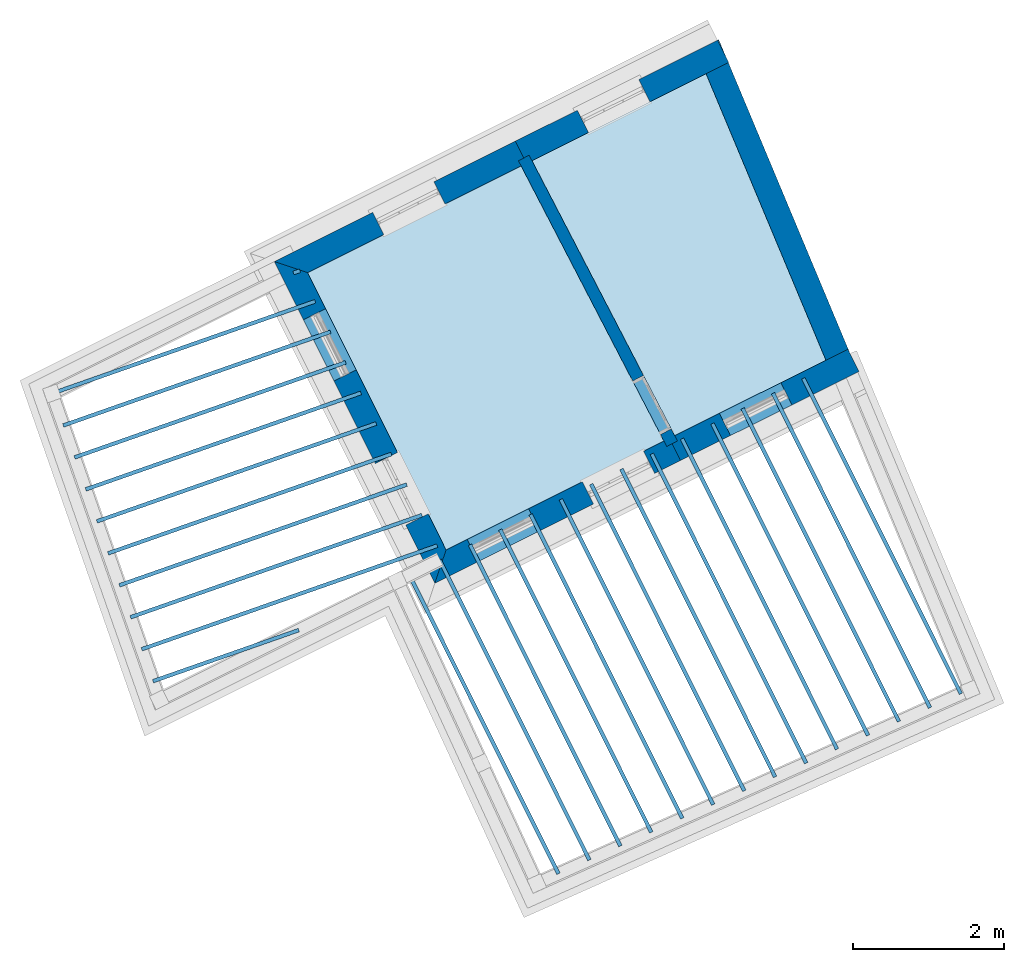
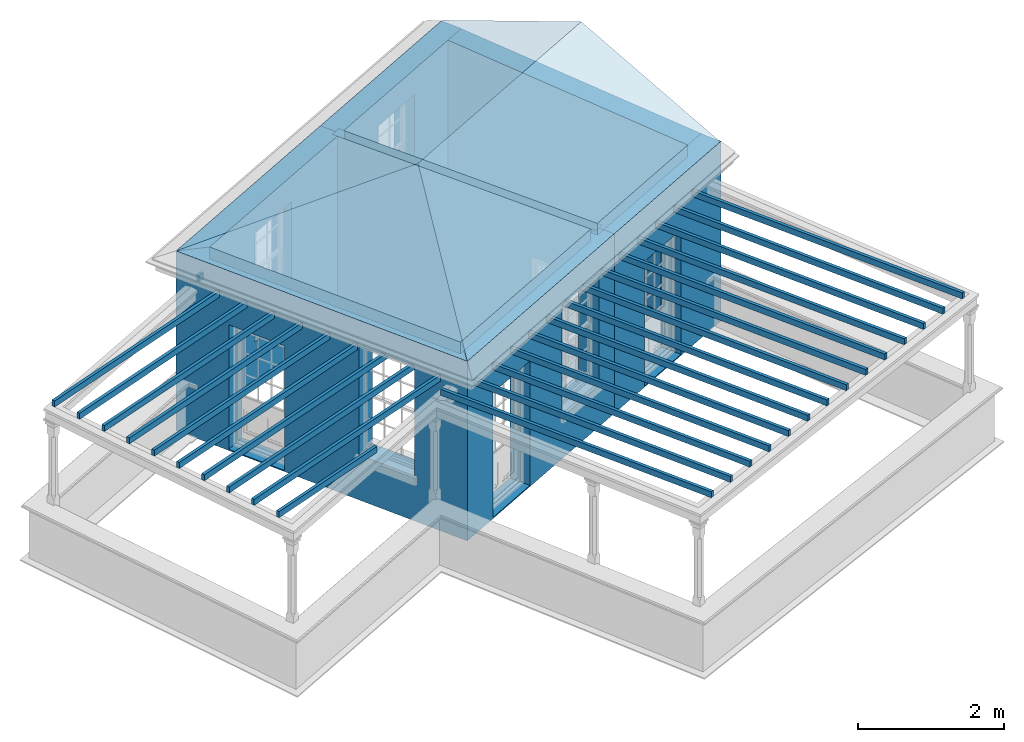
# One storey, part 1 of 7: 28 slabs, 7 walls, 1 roof, 8 openings.
"""IFC2X3 building model written with IfcOpenShell, lengths in metres."""

from ifc_helpers import new_model, si_unit, frame, origin, place, context, subcontext, project, spatial, polyline, outline, extrude, faceted_brep, material, layer, layer_set, layer_usage, element, save


model = new_model("IFC2X3")

# Units and contexts
model_context = context("Model", 3, world=origin())
body_context = subcontext(model_context, "Body", "Model", "MODEL_VIEW")
ifc_project = project(units=[si_unit("PLANEANGLEUNIT", "RADIAN"), si_unit("MASSUNIT", "GRAM", prefix="KILO"), si_unit("FORCEUNIT", "NEWTON", prefix="KILO"), si_unit("LENGTHUNIT", "METRE")], contexts=[model_context])

# Site, building, storey
site_placement = place(None, origin())
site = spatial("IfcSite", under=ifc_project, at=site_placement, CompositionType="ELEMENT")
building_placement = place(None, origin())
building = spatial("IfcBuilding", under=site, at=building_placement, Name="Building plot-8", CompositionType="ELEMENT")
storey_placement = place(None, frame((0.0, 0.0, 6.3)))
storey = spatial("IfcBuildingStorey", under=building, at=storey_placement, Name="Floor 2", CompositionType="ELEMENT", Elevation=6.3)

# Slabs
slab_1_placement = place(storey_placement, frame((0.0, 0.0, 2.8)))
element("IfcSlab", 1, at=slab_1_placement, inside=storey, Name="Slab", ObjectType="Slab", PredefinedType="FLOOR", context=body_context, shape_type="SweptSolid", body=[
    extrude(outline(polyline([(27.480706150414, 14.9772635263), (29.4890486291312, 15.9799160247855), (27.8974321953213, 19.7854722025051), (25.5844795437758, 18.6307449687159), (27.480706150414, 14.9772635263)])), origin(), (0.0, 0.0, 1.0), 0.2),
])
slab_2_placement = place(storey_placement, frame((0.0, 0.0, 2.5)))
element("IfcSlab", 2, at=slab_2_placement, inside=storey, Name="Slab", ObjectType="Slab", PredefinedType="FLOOR", context=body_context, shape_type="SweptSolid", body=[
    extrude(outline(polyline([(29.2114755475068, 15.7519237089368), (29.1667406644504, 15.7295900966464), (31.2601553460307, 11.5364188464489), (31.304890229087, 11.5587524587392), (29.2114755475068, 15.7519237089368)])), origin(), (0.0, 0.0, 1.0), 0.1),
])
slab_3_placement = place(storey_placement, frame((0.0, 0.0, 2.5)))
element("IfcSlab", 3, at=slab_3_placement, inside=storey, Name="Slab", ObjectType="Slab", PredefinedType="FLOOR", context=body_context, shape_type="SweptSolid", body=[
    extrude(outline(polyline([(28.8088615999997, 15.5509211983237), (28.7641267169434, 15.5285875860334), (30.848959669943, 11.3526057908817), (30.8936945529993, 11.374939403172), (28.8088615999997, 15.5509211983237)])), origin(), (0.0, 0.0, 1.0), 0.1),
])
slab_4_placement = place(storey_placement, frame((0.0, 0.0, 2.5)))
element("IfcSlab", 4, at=slab_4_placement, inside=storey, Name="Slab", ObjectType="Slab", PredefinedType="FLOOR", context=body_context, shape_type="SweptSolid", body=[
    extrude(outline(polyline([(28.4062476524926, 15.3499186877106), (28.3615127694363, 15.3275850754203), (30.4377639938553, 11.1687927353144), (30.4824988769116, 11.1911263476048), (28.4062476524926, 15.3499186877106)])), origin(), (0.0, 0.0, 1.0), 0.1),
])
slab_5_placement = place(storey_placement, frame((0.0, 0.0, 2.5)))
element("IfcSlab", 5, at=slab_5_placement, inside=storey, Name="Slab", ObjectType="Slab", PredefinedType="FLOOR", context=body_context, shape_type="SweptSolid", body=[
    extrude(outline(polyline([(28.0036337049855, 15.1489161770975), (27.9588988219292, 15.1265825648072), (30.0265683177675, 10.9849796797472), (30.0713032008239, 11.0073132920375), (28.0036337049855, 15.1489161770975)])), origin(), (0.0, 0.0, 1.0), 0.1),
])
slab_6_placement = place(storey_placement, frame((0.0, 0.0, 2.5)))
element("IfcSlab", 6, at=slab_6_placement, inside=storey, Name="Slab", ObjectType="Slab", PredefinedType="FLOOR", context=body_context, shape_type="SweptSolid", body=[
    extrude(outline(polyline([(27.6010197574785, 14.9479136664844), (27.5562848744221, 14.9255800541941), (29.6153726416798, 10.8011666241799), (29.6601075247362, 10.8235002364703), (27.6010197574785, 14.9479136664844)])), origin(), (0.0, 0.0, 1.0), 0.1),
])
slab_7_placement = place(storey_placement, frame((0.0, 0.0, 2.5)))
element("IfcSlab", 7, at=slab_7_placement, inside=storey, Name="Slab", ObjectType="Slab", PredefinedType="FLOOR", context=body_context, shape_type="SweptSolid", body=[
    extrude(outline(polyline([(27.1984058099714, 14.7469111558714), (27.153670926915, 14.724577543581), (29.2041769655921, 10.6173535686127), (29.2489118486484, 10.639687180903), (27.1984058099714, 14.7469111558714)])), origin(), (0.0, 0.0, 1.0), 0.1),
])
slab_8_placement = place(storey_placement, frame((0.0, 0.0, 2.5)))
element("IfcSlab", 8, at=slab_8_placement, inside=storey, Name="Slab", ObjectType="Slab", PredefinedType="FLOOR", context=body_context, shape_type="SweptSolid", body=[
    extrude(outline(polyline([(26.7957918624643, 14.5459086452583), (26.7510569794079, 14.5235750329679), (28.7929812895044, 10.4335405130455), (28.8377161725607, 10.4558741253358), (26.7957918624643, 14.5459086452583)])), origin(), (0.0, 0.0, 1.0), 0.1),
])
slab_9_placement = place(storey_placement, frame((0.0, 0.0, 2.5)))
element("IfcSlab", 9, at=slab_9_placement, inside=storey, Name="Slab", ObjectType="Slab", PredefinedType="FLOOR", context=body_context, shape_type="SweptSolid", body=[
    extrude(outline(polyline([(26.3931779149572, 14.3449061346452), (26.3484430319009, 14.3225725223549), (28.3817856134166, 10.2497274574782), (28.426520496473, 10.2720610697686), (26.3931779149572, 14.3449061346452)])), origin(), (0.0, 0.0, 1.0), 0.1),
])
slab_10_placement = place(storey_placement, frame((0.0, 0.0, 2.5)))
element("IfcSlab", 10, at=slab_10_placement, inside=storey, Name="Slab", ObjectType="Slab", PredefinedType="FLOOR", context=body_context, shape_type="SweptSolid", body=[
    extrude(outline(polyline([(25.9905639674501, 14.1439036240321), (25.9458290843938, 14.1215700117418), (27.9705899373289, 10.065914401911), (28.0153248203853, 10.0882480142013), (25.9905639674501, 14.1439036240321)])), origin(), (0.0, 0.0, 1.0), 0.1),
])
slab_11_placement = place(storey_placement, frame((0.0, 0.0, 2.5)))
element("IfcSlab", 11, at=slab_11_placement, inside=storey, Name="Slab", ObjectType="Slab", PredefinedType="FLOOR", context=body_context, shape_type="SweptSolid", body=[
    extrude(outline(polyline([(25.587950019943, 13.942901113419), (25.5432151368867, 13.9205675011287), (27.5593942612412, 9.88210134634374), (27.6041291442975, 9.90443495863409), (25.587950019943, 13.942901113419)])), origin(), (0.0, 0.0, 1.0), 0.1),
])
slab_12_placement = place(storey_placement, frame((0.0, 0.0, 2.5)))
element("IfcSlab", 12, at=slab_12_placement, inside=storey, Name="Slab", ObjectType="Slab", PredefinedType="FLOOR", context=body_context, shape_type="SweptSolid", body=[
    extrude(outline(polyline([(25.1853360724359, 13.7418986028059), (25.1406011893796, 13.7195649905156), (27.1481985851535, 9.69828829077649), (27.1929334682098, 9.72062190306683), (25.1853360724359, 13.7418986028059)])), origin(), (0.0, 0.0, 1.0), 0.1),
])
slab_13_placement = place(storey_placement, frame((0.0, 0.0, 2.5)))
element("IfcSlab", 13, at=slab_13_placement, inside=storey, Name="Slab", ObjectType="Slab", PredefinedType="FLOOR", context=body_context, shape_type="SweptSolid", body=[
    extrude(outline(polyline([(24.7827221249289, 13.5408960921929), (24.7379872418725, 13.5185624799025), (26.7370029090658, 9.51447523520926), (26.7817377921221, 9.5368088474996), (24.7827221249289, 13.5408960921929)])), origin(), (0.0, 0.0, 1.0), 0.1),
])
slab_14_placement = place(storey_placement, frame((0.0, 0.0, 2.5)))
element("IfcSlab", 14, at=slab_14_placement, inside=storey, Name="Slab", ObjectType="Slab", PredefinedType="FLOOR", context=body_context, shape_type="SweptSolid", body=[
    extrude(outline(polyline([(24.3801081774218, 13.3398935815798), (24.3353732943654, 13.3175599692894), (26.325807232978, 9.33066217964202), (26.3705421160344, 9.35299579193236), (24.3801081774218, 13.3398935815798)])), origin(), (0.0, 0.0, 1.0), 0.1),
])
slab_15_placement = place(storey_placement, frame((0.0, 0.0, 2.5)))
element("IfcSlab", 15, at=slab_15_placement, inside=storey, Name="Slab", ObjectType="Slab", PredefinedType="FLOOR", context=body_context, shape_type="SweptSolid", body=[
    extrude(outline(polyline([(23.9774942299147, 13.1388910709667), (23.9327593468584, 13.1165574586764), (25.9146115568903, 9.14684912407477), (25.9593464399467, 9.16918273636511), (23.9774942299147, 13.1388910709667)])), origin(), (0.0, 0.0, 1.0), 0.1),
])
slab_16_placement = place(storey_placement, frame((0.0, 0.0, 2.8)))
element("IfcSlab", 16, at=slab_16_placement, inside=storey, Name="Slab", ObjectType="Slab", PredefinedType="FLOOR", context=body_context, shape_type="SweptSolid", body=[
    extrude(outline(polyline([(24.4433832878594, 13.4608989674064), (27.3375368702061, 14.9057871531076), (25.4413102635679, 18.5592685955235), (22.6049906081901, 17.1432536383612), (24.4433832878594, 13.4608989674064)])), origin(), (0.0, 0.0, 1.0), 0.2),
])
slab_17_placement = place(storey_placement, frame((0.0, 0.0, 2.5)))
element("IfcSlab", 17, at=slab_17_placement, inside=storey, Name="Slab", ObjectType="Slab", PredefinedType="FLOOR", context=body_context, shape_type="SweptSolid", body=[
    extrude(outline(polyline([(22.4078207937473, 17.1619546701759), (22.4243592819192, 17.114769096014), (22.5111068779898, 17.1451740262716), (22.4945683898179, 17.1923596004335), (22.4078207937473, 17.1619546701759)])), origin(), (0.0, 0.0, 1.0), 0.1),
])
slab_18_placement = place(storey_placement, frame((0.0, 0.0, 2.5)))
element("IfcSlab", 18, at=slab_18_placement, inside=storey, Name="Slab", ObjectType="Slab", PredefinedType="FLOOR", context=body_context, shape_type="SweptSolid", body=[
    extrude(outline(polyline([(19.2020607612667, 15.5614989012153), (19.2185992494385, 15.5143133270535), (22.7137136023253, 16.7393467914407), (22.6971751141534, 16.7865323656026), (19.2020607612667, 15.5614989012153)])), origin(), (0.0, 0.0, 1.0), 0.1),
])
slab_19_placement = place(storey_placement, frame((0.0, 0.0, 2.5)))
element("IfcSlab", 19, at=slab_19_placement, inside=storey, Name="Slab", ObjectType="Slab", PredefinedType="FLOOR", context=body_context, shape_type="SweptSolid", body=[
    extrude(outline(polyline([(19.3509071548137, 15.1368287337583), (19.3674456429856, 15.0896431595964), (22.9163203266607, 16.3335195566098), (22.8997818384888, 16.3807051307717), (19.3509071548137, 15.1368287337583)])), origin(), (0.0, 0.0, 1.0), 0.1),
])
slab_20_placement = place(storey_placement, frame((0.0, 0.0, 2.5)))
element("IfcSlab", 20, at=slab_20_placement, inside=storey, Name="Slab", ObjectType="Slab", PredefinedType="FLOOR", context=body_context, shape_type="SweptSolid", body=[
    extrude(outline(polyline([(19.4997535483608, 14.7121585663012), (19.5162920365327, 14.6649729921393), (23.1189270509962, 15.9276923217789), (23.1023885628243, 15.9748778959408), (19.4997535483608, 14.7121585663012)])), origin(), (0.0, 0.0, 1.0), 0.1),
])
slab_21_placement = place(storey_placement, frame((0.0, 0.0, 2.5)))
element("IfcSlab", 21, at=slab_21_placement, inside=storey, Name="Slab", ObjectType="Slab", PredefinedType="FLOOR", context=body_context, shape_type="SweptSolid", body=[
    extrude(outline(polyline([(19.6485999419079, 14.2874883988441), (19.6651384300798, 14.2403028246822), (23.3215337753317, 15.521865086948), (23.3049952871598, 15.5690506611099), (19.6485999419079, 14.2874883988441)])), origin(), (0.0, 0.0, 1.0), 0.1),
])
slab_22_placement = place(storey_placement, frame((0.0, 0.0, 2.5)))
element("IfcSlab", 22, at=slab_22_placement, inside=storey, Name="Slab", ObjectType="Slab", PredefinedType="FLOOR", context=body_context, shape_type="SweptSolid", body=[
    extrude(outline(polyline([(19.797446335455, 13.862818231387), (19.8139848236269, 13.8156326572251), (23.5241404996671, 15.1160378521171), (23.5076020114952, 15.163223426279), (19.797446335455, 13.862818231387)])), origin(), (0.0, 0.0, 1.0), 0.1),
])
slab_23_placement = place(storey_placement, frame((0.0, 0.0, 2.5)))
element("IfcSlab", 23, at=slab_23_placement, inside=storey, Name="Slab", ObjectType="Slab", PredefinedType="FLOOR", context=body_context, shape_type="SweptSolid", body=[
    extrude(outline(polyline([(19.9462927290021, 13.4381480639299), (19.962831217174, 13.390962489768), (23.7267472240026, 14.7102106172863), (23.7102087358307, 14.7573961914481), (19.9462927290021, 13.4381480639299)])), origin(), (0.0, 0.0, 1.0), 0.1),
])
slab_24_placement = place(storey_placement, frame((0.0, 0.0, 2.5)))
element("IfcSlab", 24, at=slab_24_placement, inside=storey, Name="Slab", ObjectType="Slab", PredefinedType="FLOOR", context=body_context, shape_type="SweptSolid", body=[
    extrude(outline(polyline([(20.0951391225492, 13.0134778964729), (20.1116776107211, 12.966292322311), (23.929353948338, 14.3043833824554), (23.9128154601661, 14.3515689566173), (20.0951391225492, 13.0134778964729)])), origin(), (0.0, 0.0, 1.0), 0.1),
])
slab_25_placement = place(storey_placement, frame((0.0, 0.0, 2.5)))
element("IfcSlab", 25, at=slab_25_placement, inside=storey, Name="Slab", ObjectType="Slab", PredefinedType="FLOOR", context=body_context, shape_type="SweptSolid", body=[
    extrude(outline(polyline([(20.2439855160963, 12.5888077290158), (20.2605240042682, 12.5416221548539), (24.1319606726735, 13.8985561476245), (24.1154221845016, 13.9457417217864), (20.2439855160963, 12.5888077290158)])), origin(), (0.0, 0.0, 1.0), 0.1),
])
slab_26_placement = place(storey_placement, frame((0.0, 0.0, 2.5)))
element("IfcSlab", 26, at=slab_26_placement, inside=storey, Name="Slab", ObjectType="Slab", PredefinedType="FLOOR", context=body_context, shape_type="SweptSolid", body=[
    extrude(outline(polyline([(20.3928319096434, 12.1641375615587), (20.4093703978153, 12.1169519873968), (24.334567397009, 13.4927289127936), (24.3180289088371, 13.5399144869555), (20.3928319096434, 12.1641375615587)])), origin(), (0.0, 0.0, 1.0), 0.1),
])
slab_27_placement = place(storey_placement, frame((0.0, 0.0, 2.5)))
element("IfcSlab", 27, at=slab_27_placement, inside=storey, Name="Slab", ObjectType="Slab", PredefinedType="FLOOR", context=body_context, shape_type="SweptSolid", body=[
    extrude(outline(polyline([(20.5416783031905, 11.7394673941016), (20.5582167913623, 11.6922818199397), (22.4955255127039, 12.3713062451442), (22.478987024532, 12.4184918193061), (20.5416783031905, 11.7394673941016)])), origin(), (0.0, 0.0, 1.0), 0.1),
])
slab_28_placement = place(storey_placement, origin())
element("IfcSlab", 28, at=slab_28_placement, inside=storey, Name="Slab", ObjectType="Slab", PredefinedType="FLOOR", context=body_context, shape_type="SweptSolid", body=[
    extrude(outline(polyline([(27.480706150414, 14.9772635263), (29.4890486291312, 15.9799160247855), (27.8974321953213, 19.7854722025051), (25.5844795437758, 18.6307449687159), (27.480706150414, 14.9772635263)])), origin(), (0.0, 0.0, 1.0), 0.02),
])

# Wall, opening
ifc_material_1 = material(Name="Masonry")
ifc_layer_1 = layer(ifc_material_1, 0.33, ventilated=False)
ifc_layer_set_1 = layer_set([ifc_layer_1], Name="My Wall")
ifc_layer_usage_1 = layer_usage(ifc_layer_set_1, "AXIS2", "NEGATIVE", 0.08)
wall_1_placement = place(storey_placement, origin())
wall_1 = element("IfcWallStandardCase", 29, at=wall_1_placement, inside=storey, material=ifc_layer_usage_1, Name="exterior", context=body_context, shape_type="SweptSolid", body=[
    extrude(outline(polyline([(28.1976396877446, 19.9353489269842), (28.0502378466283, 20.230599155156), (25.3643689149095, 18.889695786567), (25.5117707560258, 18.5944455583952), (28.1976396877446, 19.9353489269842)])), origin(), (0.0, 0.0, 1.0), 3.0),
])
opening_1_placement = place(storey_placement, frame((0.0, 0.0, 0.75)))
element("IfcOpeningElement", 30, at=opening_1_placement, cuts=wall_1, Name="Opening", ObjectType="Opening", context=body_context, shape_type="SweptSolid", body=[
    extrude(outline(polyline([(27.0025536089408, 19.7075493119778), (26.1883787373153, 19.3010775682935), (26.3357805784316, 19.0058273401217), (27.149955450057, 19.4122990838059), (27.0025536089408, 19.7075493119778)])), origin(), (0.0, 0.0, 1.0), 1.82),
])

wall_2_placement = place(storey_placement, origin())
wall_2 = element("IfcWallStandardCase", 31, at=wall_2_placement, inside=storey, material=ifc_layer_usage_1, Name="exterior", context=body_context, shape_type="SweptSolid", body=[
    extrude(outline(polyline([(25.5117707560258, 18.5944455583952), (25.3643689149095, 18.889695786567), (22.162338538902, 17.2911020254168), (22.6049906081901, 17.1432536383612), (25.5117707560258, 18.5944455583952)])), origin(), (0.0, 0.0, 1.0), 3.0),
])
opening_2_placement = place(storey_placement, frame((0.0, 0.0, 0.75)))
element("IfcOpeningElement", 32, at=opening_2_placement, cuts=wall_2, Name="Opening", ObjectType="Opening", context=body_context, shape_type="SweptSolid", body=[
    extrude(outline(polyline([(24.2822783703593, 18.3494688085599), (23.4681034987339, 17.9429970648756), (23.6155053398501, 17.6477468367038), (24.4296802114756, 18.054218580388), (24.2822783703593, 18.3494688085599)])), origin(), (0.0, 0.0, 1.0), 1.82),
])

# Wall, openings
wall_3_placement = place(storey_placement, origin())
wall_3 = element("IfcWallStandardCase", 33, at=wall_3_placement, inside=storey, material=ifc_layer_usage_1, Name="exterior", context=body_context, shape_type="SweptSolid", body=[
    extrude(outline(polyline([(22.6049906081901, 17.1432536383612), (22.162338538902, 17.2911020254168), (24.2955349008038, 13.0182468981183), (24.4433832878594, 13.4608989674064), (22.6049906081901, 17.1432536383612)])), origin(), (0.0, 0.0, 1.0), 3.0),
])
opening_3_placement = place(storey_placement, frame((0.0, 0.0, 0.0199999999999996)))
element("IfcOpeningElement", 34, at=opening_3_placement, cuts=wall_3, Name="Opening", ObjectType="Opening", context=body_context, shape_type="SweptSolid", body=[
    extrude(outline(polyline([(22.5482357882612, 16.518138471764), (22.9547075319454, 15.7039636001386), (23.2499577601173, 15.8513654412549), (22.843486016433, 16.6655403128803), (22.5482357882612, 16.518138471764)])), origin(), (0.0, 0.0, 1.0), 2.08),
])
opening_4_placement = place(storey_placement, frame((0.0, 0.0, 0.75)))
element("IfcOpeningElement", 35, at=opening_4_placement, cuts=wall_3, Name="Opening", ObjectType="Opening", context=body_context, shape_type="SweptSolid", body=[
    extrude(outline(polyline([(23.5031659077604, 14.6053853233965), (23.9096376514446, 13.791210451771), (24.2048878796165, 13.9386122928873), (23.7984161359322, 14.7527871645127), (23.5031659077604, 14.6053853233965)])), origin(), (0.0, 0.0, 1.0), 1.82),
])

wall_4_placement = place(storey_placement, origin())
wall_4 = element("IfcWallStandardCase", 36, at=wall_4_placement, inside=storey, material=ifc_layer_usage_1, Name="exterior", context=body_context, shape_type="SweptSolid", body=[
    extrude(outline(polyline([(24.4433832878594, 13.4608989674064), (24.2955349008038, 13.0182468981183), (27.5576474990724, 14.6468363352565), (27.4102456579562, 14.9420865634283), (24.4433832878594, 13.4608989674064)])), origin(), (0.0, 0.0, 1.0), 3.0),
])
opening_5_placement = place(storey_placement, frame((0.0, 0.0, 0.0199999999999996)))
element("IfcOpeningElement", 37, at=opening_5_placement, cuts=wall_4, Name="Opening", ObjectType="Opening", context=body_context, shape_type="SweptSolid", body=[
    extrude(outline(polyline([(24.8717314260195, 13.3059094316495), (25.685906297645, 13.7123811753337), (25.5385044565287, 14.0076314035056), (24.7243295849033, 13.6011596598214), (24.8717314260195, 13.3059094316495)])), origin(), (0.0, 0.0, 1.0), 2.08),
])
opening_6_placement = place(storey_placement, frame((0.0, 0.0, 0.75)))
element("IfcOpeningElement", 38, at=opening_6_placement, cuts=wall_4, Name="Opening", ObjectType="Opening", context=body_context, shape_type="SweptSolid", body=[
    extrude(outline(polyline([(26.4016644265464, 14.0697189719792), (27.2158392981719, 14.4761907156634), (27.0684374570556, 14.7714409438353), (26.2542625854302, 14.3649692001511), (26.4016644265464, 14.0697189719792)])), origin(), (0.0, 0.0, 1.0), 1.82),
])

# Wall, opening
wall_5_placement = place(storey_placement, origin())
wall_5 = element("IfcWallStandardCase", 39, at=wall_5_placement, inside=storey, material=ifc_layer_usage_1, Name="exterior", context=body_context, shape_type="SweptSolid", body=[
    extrude(outline(polyline([(27.4102456579562, 14.9420865634283), (27.5576474990724, 14.6468363352565), (29.9270645302191, 15.8297530595747), (29.7796626891029, 16.1250032877466), (27.4102456579562, 14.9420865634283)])), origin(), (0.0, 0.0, 1.0), 3.0),
])
opening_7_placement = place(storey_placement, frame((0.0, 0.0, 0.0199999999999996)))
element("IfcOpeningElement", 40, at=opening_7_placement, cuts=wall_5, Name="Opening", ObjectType="Opening", context=body_context, shape_type="SweptSolid", body=[
    extrude(outline(polyline([(28.2234313711922, 14.9792247948476), (29.0376062428176, 15.3856965385319), (28.8902044017014, 15.6809467667037), (28.0760295300759, 15.2744750230195), (28.2234313711922, 14.9792247948476)])), origin(), (0.0, 0.0, 1.0), 2.08),
])

# Wall
wall_6_placement = place(storey_placement, origin())
element("IfcWallStandardCase", 41, at=wall_6_placement, inside=storey, material=ifc_layer_usage_1, Name="party", context=body_context, shape_type="SweptSolid", body=[
    extrude(outline(polyline([(29.517917058027, 15.910891587998), (29.8223626642942, 16.0382213678007), (28.1688721036068, 19.9917186328186), (27.8644264973396, 19.8643888530159), (29.517917058027, 15.910891587998)])), origin(), (0.0, 0.0, 1.0), 3.0),
])

# Wall, opening
ifc_material_2 = material(Name="Masonry")
ifc_layer_2 = layer(ifc_material_2, 0.16, ventilated=False)
ifc_layer_set_2 = layer_set([ifc_layer_2], Name="My Wall")
ifc_layer_usage_2 = layer_usage(ifc_layer_set_2, "AXIS2", "NEGATIVE", 0.08)
wall_7_placement = place(storey_placement, origin())
wall_7 = element("IfcWallStandardCase", 42, at=wall_7_placement, inside=storey, material=ifc_layer_usage_2, Name="interior", context=body_context, shape_type="SweptSolid", body=[
    extrude(outline(polyline([(25.5470428086069, 18.7028747535873), (25.4050311441155, 18.6291679889833), (27.374973605375, 14.8336573682362), (27.5169852698664, 14.9073641328402), (25.5470428086069, 18.7028747535873)])), origin(), (0.0, 0.0, 1.0), 3.0),
])
opening_8_placement = place(storey_placement, frame((0.0, 0.0, 0.0199999999999996)))
element("IfcOpeningElement", 43, at=opening_8_placement, cuts=wall_7, Name="Opening", ObjectType="Opening", context=body_context, shape_type="SweptSolid", body=[
    extrude(outline(polyline([(26.9235196721751, 15.7034788132456), (27.2920534951955, 14.9934204907889), (27.4340651596868, 15.067127255393), (27.0655313366665, 15.7771855778497), (26.9235196721751, 15.7034788132456)])), origin(), (0.0, 0.0, 1.0), 2.1),
])

# Roof
roof_placement = place(building_placement, origin())
element("IfcRoof", 44, at=roof_placement, inside=storey, Name="Roof", ShapeType="FREEFORM", context=body_context, shape_type="Brep", held_by="IfcProductRepresentation", body=[
    faceted_brep([(24.295535, 13.018247, 9.3), (29.912577, 15.82252, 9.3), (28.989153, 18.030427, 10.289091), (25.365364, 16.221273, 10.289091), (28.065729, 20.238333, 9.3), (22.162339, 17.291102, 9.3)], [[[0, 1, 2, 3]], [[4, 5, 3, 2]], [[5, 4, 1, 0]], [[5, 0, 3]], [[1, 4, 2]]]),
])

save(model, "model.ifc")
